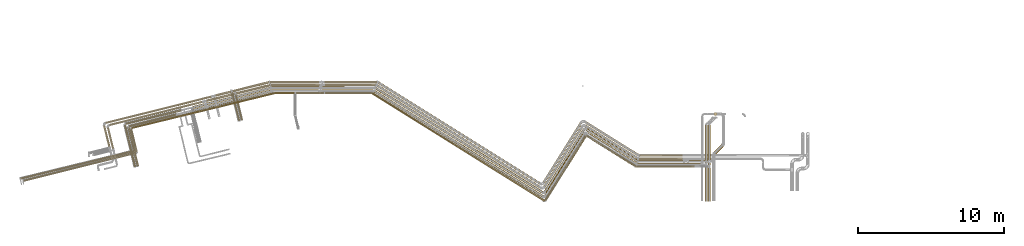
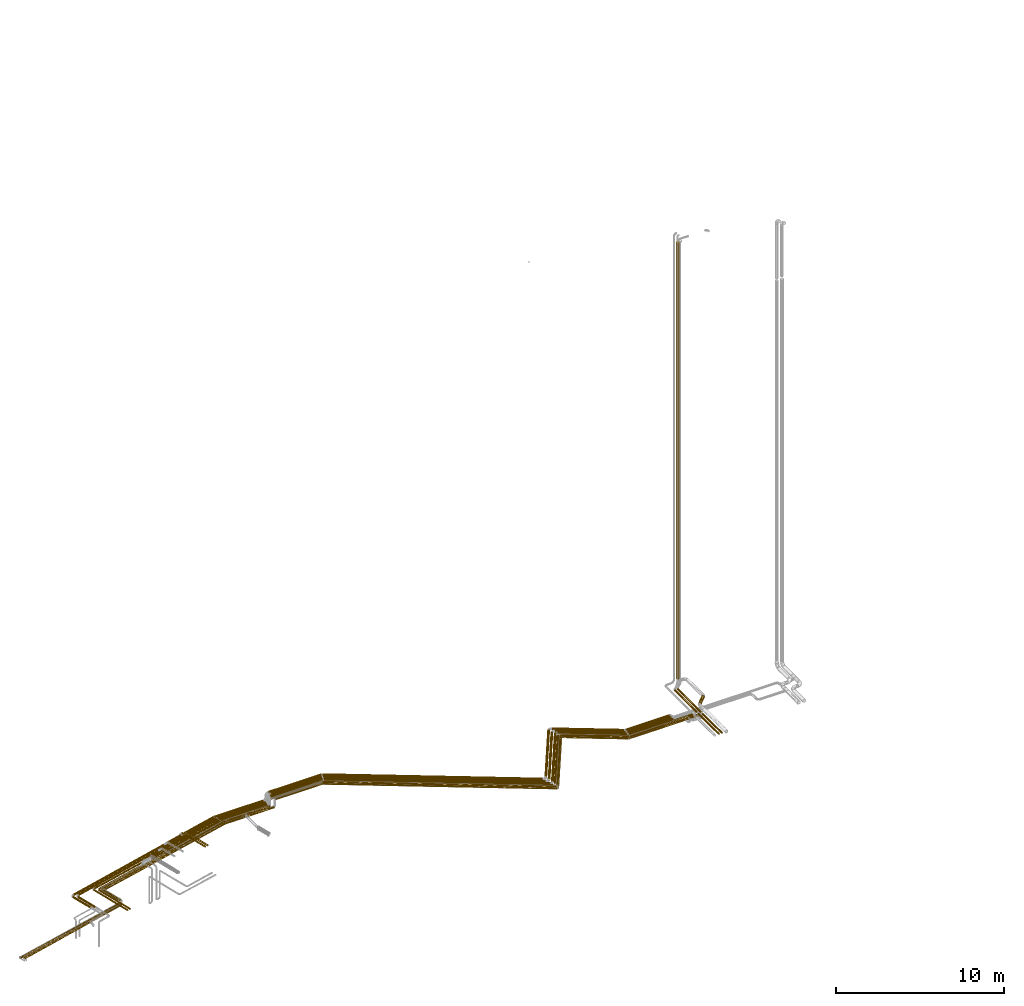
# One storey, part 1 of 93: 66 coverings.
"""IFC2X3 building model written with IfcOpenShell, lengths in millimetres."""

from ifc_helpers import new_model, entity, si_unit, converted_unit, derived_unit, direction, frame, origin, origin_2d_with_axis, place, context, subcontext, project, spatial, circle, extrude, element, save


model = new_model("IFC2X3")

# Units and contexts
model_context = context("Model", 3, precision=0.01, world=origin(), true_north=direction((6.12303176911189e-17, 1.0)))
body_context = subcontext(model_context, "Body", "Model", "MODEL_VIEW")
ifc_project = project(units=[si_unit("LENGTHUNIT", "METRE", prefix="MILLI"), si_unit("AREAUNIT", "SQUARE_METRE"), si_unit("VOLUMEUNIT", "CUBIC_METRE"), converted_unit("PLANEANGLEUNIT", "DEGREE", entity("IfcRatioMeasure", 0.0174532925199433), si_unit("PLANEANGLEUNIT", "RADIAN"), dimensions=[0, 0, 0, 0, 0, 0, 0]), si_unit("MASSUNIT", "GRAM", prefix="KILO"), derived_unit("MASSDENSITYUNIT", [(si_unit("MASSUNIT", "GRAM", prefix="KILO"), 1), (si_unit("LENGTHUNIT", "METRE"), -3)]), derived_unit("MOMENTOFINERTIAUNIT", [(si_unit("LENGTHUNIT", "METRE"), 4)]), si_unit("TIMEUNIT", "SECOND"), si_unit("FREQUENCYUNIT", "HERTZ"), si_unit("THERMODYNAMICTEMPERATUREUNIT", "DEGREE_CELSIUS"), derived_unit("THERMALTRANSMITTANCEUNIT", [(si_unit("MASSUNIT", "GRAM", prefix="KILO"), 1), (si_unit("THERMODYNAMICTEMPERATUREUNIT", "KELVIN"), -1), (si_unit("TIMEUNIT", "SECOND"), -3)]), derived_unit("VOLUMETRICFLOWRATEUNIT", [(si_unit("LENGTHUNIT", "METRE"), 3), (si_unit("TIMEUNIT", "SECOND"), -1)]), derived_unit("MASSFLOWRATEUNIT", [(si_unit("MASSUNIT", "GRAM", prefix="KILO"), 1), (si_unit("TIMEUNIT", "SECOND"), -1)]), derived_unit("ROTATIONALFREQUENCYUNIT", [(si_unit("TIMEUNIT", "SECOND"), -1)]), si_unit("ELECTRICCURRENTUNIT", "AMPERE"), si_unit("ELECTRICVOLTAGEUNIT", "VOLT"), si_unit("POWERUNIT", "WATT"), si_unit("FORCEUNIT", "NEWTON", prefix="KILO"), si_unit("ILLUMINANCEUNIT", "LUX"), si_unit("LUMINOUSFLUXUNIT", "LUMEN"), si_unit("LUMINOUSINTENSITYUNIT", "CANDELA"), derived_unit("USERDEFINED", [(si_unit("MASSUNIT", "GRAM", prefix="KILO"), -1), (si_unit("LENGTHUNIT", "METRE"), -2), (si_unit("TIMEUNIT", "SECOND"), 3), (si_unit("LUMINOUSFLUXUNIT", "LUMEN"), 1)]), derived_unit("LINEARVELOCITYUNIT", [(si_unit("LENGTHUNIT", "METRE"), 1), (si_unit("TIMEUNIT", "SECOND"), -1)]), si_unit("PRESSUREUNIT", "PASCAL"), derived_unit("USERDEFINED", [(si_unit("LENGTHUNIT", "METRE"), -2), (si_unit("MASSUNIT", "GRAM", prefix="KILO"), 1), (si_unit("TIMEUNIT", "SECOND"), -2)]), derived_unit("LINEARFORCEUNIT", [(si_unit("MASSUNIT", "GRAM", prefix="KILO"), 1), (si_unit("LENGTHUNIT", "METRE"), 1), (si_unit("TIMEUNIT", "SECOND"), -2), (si_unit("LENGTHUNIT", "METRE"), -1)]), derived_unit("PLANARFORCEUNIT", [(si_unit("MASSUNIT", "GRAM", prefix="KILO"), 1), (si_unit("LENGTHUNIT", "METRE"), 1), (si_unit("TIMEUNIT", "SECOND"), -2), (si_unit("LENGTHUNIT", "METRE"), -2)])], contexts=[model_context])

# Site, building, storey
site_placement = place(None, origin())
site = spatial("IfcSite", under=ifc_project, at=site_placement, CompositionType="ELEMENT")
building_placement = place(site_placement, origin())
building = spatial("IfcBuilding", under=site, at=building_placement, CompositionType="ELEMENT")
storey_placement = place(building_placement, frame((0.0, 0.0, -4200.0)))
storey = spatial("IfcBuildingStorey", under=building, at=storey_placement, CompositionType="ELEMENT", Elevation=-4200.0)

# Coverings
covering_1_placement = place(storey_placement, frame((16223.6, 8804.96, 2914.66)))
element("IfcCovering", 1, at=covering_1_placement, inside=storey, PredefinedType="INSULATION", context=body_context, shape_type="SweptSolid", body=[
    extrude(circle(Radius=84.5, at=origin_2d_with_axis()), frame((3445.16, 73.26, 86.1), z_axis=(-0.848048096872166, 0.529919263087781, 0.0), x_axis=(-0.529919263087781, -0.848048096872166, 0.0)), (0.0, 0.0, 1.0), 4007.77716045076),
])
covering_2_placement = place(storey_placement, frame((13365.87, 6651.78, 2914.66)))
element("IfcCovering", 2, at=covering_2_placement, inside=storey, PredefinedType="INSULATION", context=body_context, shape_type="SweptSolid", body=[
    extrude(circle(Radius=84.5, at=origin_2d_with_axis()), frame((73.26, 46.37, 86.1), z_axis=(0.529919264233208, 0.848048096156424, 0.0), x_axis=(0.848048096156424, -0.529919264233208, 0.0)), (0.0, 0.0, 1.0), 5029.99999999998),
])
covering_3_placement = place(storey_placement, frame((1670.12, 6586.73, 2913.9)))
element("IfcCovering", 3, at=covering_3_placement, inside=storey, PredefinedType="INSULATION", context=body_context, shape_type="SweptSolid", body=[
    extrude(circle(Radius=84.5, at=origin_2d_with_axis()), frame((11603.65, 73.26, 86.85), z_axis=(-0.848048094870504, 0.529919263429674, -5.5069602747006e-05), x_axis=(0.529919264233207, 0.848048096156425, 0.0)), (0.0, 0.0, 1.0), 13628.0909050597),
])
covering_4_placement = place(storey_placement, frame((-1871.09, 13813.91, 2913.9)))
element("IfcCovering", 4, at=covering_4_placement, inside=storey, PredefinedType="INSULATION", context=body_context, shape_type="SweptSolid", body=[
    extrude(circle(Radius=84.5, at=origin_2d_with_axis()), frame((0.0, 86.1, 86.1), z_axis=(1.0, 0.0, -7.50758540454034e-07), x_axis=(0.0, -1.0, 0.0)), (0.0, 0.0, 1.0), 3523.99516441944),
])
covering_5_placement = place(storey_placement, frame((19732.35, 8773.89, 2914.66)))
element("IfcCovering", 5, at=covering_5_placement, inside=storey, PredefinedType="INSULATION", context=body_context, shape_type="SweptSolid", body=[
    extrude(circle(Radius=84.5, at=origin_2d_with_axis()), frame((0.0, 86.1, 86.1), z_axis=(1.0, 0.0, 0.0), x_axis=(0.0, -1.0, 0.0)), (0.0, 0.0, 1.0), 4364.44138685684),
])
covering_6_placement = place(storey_placement, frame((24958.04, 9544.49, 2891.9)))
element("IfcCovering", 6, at=covering_6_placement, inside=storey, PredefinedType="INSULATION", context=body_context, shape_type="SweptSolid", body=[
    extrude(circle(Radius=106.5, at=origin_2d_with_axis()), frame((76.9, 76.9, 108.1), z_axis=(0.707106781186553, 0.707106781186542, 0.0), x_axis=(-0.707106781186542, 0.707106781186553, 0.0)), (0.0, 0.0, 1.0), 775.735931288089),
])
covering_7_placement = place(storey_placement, frame((19790.5, 8975.05, 2910.91)))
element("IfcCovering", 7, at=covering_7_placement, inside=storey, PredefinedType="INSULATION", context=body_context, shape_type="SweptSolid", body=[
    extrude(circle(Radius=84.5, at=origin_2d_with_axis()), frame((0.0, 86.1, 86.1), z_axis=(1.0, 0.0, 0.0), x_axis=(0.0, 1.0, 0.0)), (0.0, 0.0, 1.0), 3082.63986313707),
])
covering_8_placement = place(storey_placement, frame((16181.84, 9006.12, 2910.91)))
element("IfcCovering", 8, at=covering_8_placement, inside=storey, PredefinedType="INSULATION", context=body_context, shape_type="SweptSolid", body=[
    extrude(circle(Radius=84.5, at=origin_2d_with_axis()), frame((3545.07, 73.26, 86.1), z_axis=(-0.848048096872165, 0.529919263087784, 0.0), x_axis=(-0.529919263087784, -0.848048096872165, 0.0)), (0.0, 0.0, 1.0), 4125.59056056346),
])
covering_9_placement = place(storey_placement, frame((13334.7, 6932.33, 2910.91)))
element("IfcCovering", 9, at=covering_9_placement, inside=storey, PredefinedType="INSULATION", context=body_context, shape_type="SweptSolid", body=[
    extrude(circle(Radius=84.5, at=origin_2d_with_axis()), frame((73.26, 46.37, 86.1), z_axis=(0.529919264233209, 0.848048096156423, 0.0), x_axis=(0.848048096156423, -0.529919264233209, 0.0)), (0.0, 0.0, 1.0), 5010.0017049427),
])
covering_10_placement = place(storey_placement, frame((1774.02, 6867.28, 2910.91)))
element("IfcCovering", 10, at=covering_10_placement, inside=storey, PredefinedType="INSULATION", context=body_context, shape_type="SweptSolid", body=[
    extrude(circle(Radius=84.5, at=origin_2d_with_axis()), frame((11468.58, 73.26, 86.1), z_axis=(-0.848048096156424, 0.529919264233208, 0.0), x_axis=(0.0, 0.0, -1.0)), (0.0, 0.0, 1.0), 13468.8235901615),
])
covering_11_placement = place(storey_placement, frame((-1834.92, 14010.06, 2910.94)))
element("IfcCovering", 11, at=covering_11_placement, inside=storey, PredefinedType="INSULATION", context=body_context, shape_type="SweptSolid", body=[
    extrude(circle(Radius=84.5, at=origin_2d_with_axis()), frame((3591.85, 86.1, 86.1), z_axis=(-0.99999896917087, 0.00107763060458495, 0.000948878009774168), x_axis=(-0.00107763108971813, -0.999999419355449, 0.0)), (0.0, 0.0, 1.0), 3590.17075330023),
])
covering_12_placement = place(storey_placement, frame((24987.53, 12203.97, 3190.0)))
element("IfcCovering", 12, at=covering_12_placement, inside=storey, PredefinedType="INSULATION", context=body_context, shape_type="SweptSolid", body=[
    extrude(circle(Radius=110.0, at=origin_2d_with_axis()), frame((111.6, 111.6, 0.0)), (0.0, 0.0, 1.0), 31620.0),
])
covering_13_placement = place(storey_placement, frame((-7764.06, 13646.82, 2416.82)))
element("IfcCovering", 13, at=covering_13_placement, inside=storey, PredefinedType="INSULATION", context=body_context, shape_type="SweptSolid", body=[
    extrude(circle(Radius=81.5, at=origin_2d_with_axis()), frame((20.9, 80.78, 83.1), z_axis=(0.971553061175066, 0.236821975409198, 3.58419250346389e-05), x_axis=(0.236821975561314, -0.971553061799116, 0.0)), (0.0, 0.0, 1.0), 2394.20471743284),
])
covering_14_placement = place(storey_placement, frame((-16451.83, 11492.29, 2429.32)))
element("IfcCovering", 14, at=covering_14_placement, inside=storey, PredefinedType="INSULATION", context=body_context, shape_type="SweptSolid", body=[
    extrude(circle(Radius=69.0, at=origin_2d_with_axis()), frame((18.29, 68.55, 70.6), z_axis=(0.970295726276005, 0.241921895599632, 0.0), x_axis=(-0.241921895599632, 0.970295726276005, 0.0)), (0.0, 0.0, 1.0), 6535.06575644785),
])
covering_15_placement = place(storey_placement, frame((-7831.89, 11898.55, 2654.9)))
element("IfcCovering", 15, at=covering_15_placement, inside=storey, PredefinedType="INSULATION", context=body_context, shape_type="SweptSolid", body=[
    extrude(circle(Radius=43.5, at=origin_2d_with_axis()), frame((43.8, 1740.55, 45.1), z_axis=(0.241921895599631, -0.970295726276006, 0.0), x_axis=(0.970295726276006, 0.241921895599631, 0.0)), (0.0, 0.0, 1.0), 1781.33959077582),
])
covering_16_placement = place(storey_placement, frame((-9803.41, 13138.56, 2416.82)))
element("IfcCovering", 16, at=covering_16_placement, inside=storey, PredefinedType="INSULATION", context=body_context, shape_type="SweptSolid", body=[
    extrude(circle(Radius=81.5, at=origin_2d_with_axis()), frame((21.31, 80.67, 83.1), z_axis=(0.970295726276001, 0.241921895599651, 0.0), x_axis=(-0.171064612896004, 0.686102687806091, 0.707106781186546)), (0.0, 0.0, 1.0), 1971.35839123397),
])
covering_17_placement = place(storey_placement, frame((-5372.07, 14216.91, 2416.9)))
element("IfcCovering", 17, at=covering_17_placement, inside=storey, PredefinedType="INSULATION", context=body_context, shape_type="SweptSolid", body=[
    extrude(circle(Radius=81.5, at=origin_2d_with_axis()), frame((0.0, 83.1, 83.1), z_axis=(1.0, 0.0, 0.0), x_axis=(0.0, 1.0, 0.0)), (0.0, 0.0, 1.0), 3329.8857023589),
])
covering_18_placement = place(storey_placement, frame((1863.72, 7196.14, 2916.9)))
element("IfcCovering", 18, at=covering_18_placement, inside=storey, PredefinedType="INSULATION", context=body_context, shape_type="SweptSolid", body=[
    extrude(circle(Radius=81.5, at=origin_2d_with_axis()), frame((44.78, 7074.99, 83.1), z_axis=(0.848048096156426, -0.529919264233205, 0.0), x_axis=(0.529919264233205, 0.848048096156426, 0.0)), (0.0, 0.0, 1.0), 13217.6368280217),
])
covering_19_placement = place(storey_placement, frame((13308.79, 7282.51, 2916.9)))
element("IfcCovering", 19, at=covering_19_placement, inside=storey, PredefinedType="INSULATION", context=body_context, shape_type="SweptSolid", body=[
    extrude(circle(Radius=81.5, at=origin_2d_with_axis()), frame((70.71, 44.78, 83.1), z_axis=(0.529919264233208, 0.848048096156424, 0.0), x_axis=(-0.848048096156424, 0.529919264233208, 0.0)), (0.0, 0.0, 1.0), 4839.99999995205),
])
covering_20_placement = place(storey_placement, frame((16161.34, 9212.9, 2916.9)))
element("IfcCovering", 20, at=covering_20_placement, inside=storey, PredefinedType="INSULATION", context=body_context, shape_type="SweptSolid", body=[
    extrude(circle(Radius=81.5, at=origin_2d_with_axis()), frame((3579.42, 70.71, 83.1), z_axis=(-0.848048096156425, 0.529919264233206, 0.0), x_axis=(0.529919264233206, 0.848048096156425, 0.0)), (0.0, 0.0, 1.0), 4167.96244380158),
])
covering_21_placement = place(storey_placement, frame((19841.45, 9171.64, 2916.9)))
element("IfcCovering", 21, at=covering_21_placement, inside=storey, PredefinedType="INSULATION", context=body_context, shape_type="SweptSolid", body=[
    extrude(circle(Radius=81.5, at=origin_2d_with_axis()), frame((0.0, 83.1, 83.1), z_axis=(1.0, 0.0, 0.0), x_axis=(0.0, 1.0, 0.0)), (0.0, 0.0, 1.0), 3011.72234269005),
])
covering_22_placement = place(storey_placement, frame((24403.45, 8937.14, 2935.4)))
element("IfcCovering", 22, at=covering_22_placement, inside=storey, PredefinedType="INSULATION", context=body_context, shape_type="SweptSolid", body=[
    extrude(circle(Radius=63.0, at=origin_2d_with_axis()), frame((64.6, 0.0, 64.6), z_axis=(0.0, 1.0, 0.0), x_axis=(-1.0, 0.0, 0.0)), (0.0, 0.0, 1.0), 2647.17830176069),
])
covering_23_placement = place(storey_placement, frame((24403.45, 6345.74, 2935.4)))
element("IfcCovering", 23, at=covering_23_placement, inside=storey, PredefinedType="INSULATION", context=body_context, shape_type="SweptSolid", body=[
    extrude(circle(Radius=63.0, at=origin_2d_with_axis()), frame((64.6, 0.0, 64.6), z_axis=(0.0, 1.0, 0.0), x_axis=(-1.0, 0.0, 0.0)), (0.0, 0.0, 1.0), 2439.40034200199),
])
covering_24_placement = place(storey_placement, frame((19661.55, 8660.55, 2892.25)))
element("IfcCovering", 24, at=covering_24_placement, inside=storey, PredefinedType="INSULATION", context=body_context, shape_type="SweptSolid", body=[
    extrude(circle(Radius=49.0, at=origin_2d_with_axis()), frame((0.0, 50.6, 50.6), z_axis=(1.0, 0.0, 0.0), x_axis=(0.0, -1.0, 0.0)), (0.0, 0.0, 1.0), 3805.04533999816),
])
covering_25_placement = place(storey_placement, frame((16256.83, 8676.65, 2892.25)))
element("IfcCovering", 25, at=covering_25_placement, inside=storey, PredefinedType="INSULATION", context=body_context, shape_type="SweptSolid", body=[
    extrude(circle(Radius=49.0, at=origin_2d_with_axis()), frame((3374.52, 43.15, 50.6), z_axis=(-0.848048096872167, 0.529919263087781, 0.0), x_axis=(-0.529919263087781, -0.848048096872167, 0.0)), (0.0, 0.0, 1.0), 3946.65551305345),
])
covering_26_placement = place(storey_placement, frame((13407.19, 6355.78, 2892.25)))
element("IfcCovering", 26, at=covering_26_placement, inside=storey, PredefinedType="INSULATION", context=body_context, shape_type="SweptSolid", body=[
    extrude(circle(Radius=49.0, at=origin_2d_with_axis()), frame((43.15, 27.56, 50.6), z_axis=(0.529919264233211, 0.848048096156422, 0.0), x_axis=(0.848048096156422, -0.529919264233211, 0.0)), (0.0, 0.0, 1.0), 5199.86161627023),
])
covering_27_placement = place(storey_placement, frame((1539.96, 6322.06, 2892.25)))
element("IfcCovering", 27, at=covering_27_placement, inside=storey, PredefinedType="INSULATION", context=body_context, shape_type="SweptSolid", body=[
    extrude(circle(Radius=49.0, at=origin_2d_with_axis()), frame((27.56, 7419.28, 50.6), z_axis=(0.848048096156422, -0.529919264233212, 0.0), x_axis=(0.529919264233212, 0.848048096156422, 0.0)), (0.0, 0.0, 1.0), 13919.3436019751),
])
covering_28_placement = place(storey_placement, frame((-3645.84, 13699.41, 2342.25)))
element("IfcCovering", 28, at=covering_28_placement, inside=storey, PredefinedType="INSULATION", context=body_context, shape_type="SweptSolid", body=[
    extrude(circle(Radius=49.0, at=origin_2d_with_axis()), frame((0.0, 50.6, 50.6), z_axis=(1.0, 0.0, 0.0), x_axis=(0.0, 1.0, 0.0)), (0.0, 0.0, 1.0), 1883.00000000001),
])
covering_29_placement = place(storey_placement, frame((-15000.07, 10033.67, 2342.25)))
element("IfcCovering", 29, at=covering_29_placement, inside=storey, PredefinedType="INSULATION", context=body_context, shape_type="SweptSolid", body=[
    extrude(circle(Radius=49.0, at=origin_2d_with_axis()), frame((348.35, 13.05, 50.6), z_axis=(-0.233868385495283, 0.972268264557591, 0.0), x_axis=(-0.972268264557591, -0.233868385495283, 0.0)), (0.0, 0.0, 1.0), 1278.99033837842),
])
covering_30_placement = place(storey_placement, frame((24609.86, 8787.14, 2935.4)))
element("IfcCovering", 30, at=covering_30_placement, inside=storey, PredefinedType="INSULATION", context=body_context, shape_type="SweptSolid", body=[
    extrude(circle(Radius=63.0, at=origin_2d_with_axis()), frame((64.6, 0.0, 64.6), z_axis=(0.0, 1.0, 0.0), x_axis=(-1.0, 0.0, 0.0)), (0.0, 0.0, 1.0), 2807.17830176069),
])
covering_31_placement = place(storey_placement, frame((24609.86, 6345.74, 2935.4)))
element("IfcCovering", 31, at=covering_31_placement, inside=storey, PredefinedType="INSULATION", context=body_context, shape_type="SweptSolid", body=[
    extrude(circle(Radius=63.0, at=origin_2d_with_axis()), frame((64.6, 0.0, 64.6), z_axis=(0.0, 1.0, 0.0), x_axis=(-1.0, 0.0, 0.0)), (0.0, 0.0, 1.0), 2289.40034200199),
])
covering_32_placement = place(storey_placement, frame((19692.0, 8660.55, 3008.21)))
element("IfcCovering", 32, at=covering_32_placement, inside=storey, PredefinedType="INSULATION", context=body_context, shape_type="SweptSolid", body=[
    extrude(circle(Radius=49.0, at=origin_2d_with_axis()), frame((0.0, 50.6, 50.6), z_axis=(1.0, 0.0, 0.0), x_axis=(0.0, -1.0, 0.0)), (0.0, 0.0, 1.0), 3960.04533999814),
])
covering_33_placement = place(storey_placement, frame((16236.4, 8676.65, 3008.21)))
element("IfcCovering", 33, at=covering_33_placement, inside=storey, PredefinedType="INSULATION", context=body_context, shape_type="SweptSolid", body=[
    extrude(circle(Radius=49.0, at=origin_2d_with_axis()), frame((27.56, 2166.35, 50.6), z_axis=(0.848048096872167, -0.529919263087781, 0.0), x_axis=(-0.529919263087781, -0.848048096872167, 0.0)), (0.0, 0.0, 1.0), 4006.65551305341),
])
covering_34_placement = place(storey_placement, frame((13378.21, 6373.89, 3008.21)))
element("IfcCovering", 34, at=covering_34_placement, inside=storey, PredefinedType="INSULATION", context=body_context, shape_type="SweptSolid", body=[
    extrude(circle(Radius=49.0, at=origin_2d_with_axis()), frame((43.15, 27.56, 50.6), z_axis=(0.52991926423321, 0.848048096156423, 0.0), x_axis=(0.848048096156423, -0.52991926423321, 0.0)), (0.0, 0.0, 1.0), 5215.99892406455),
])
covering_35_placement = place(storey_placement, frame((1540.46, 6340.17, 3008.21)))
element("IfcCovering", 35, at=covering_35_placement, inside=storey, PredefinedType="INSULATION", context=body_context, shape_type="SweptSolid", body=[
    extrude(circle(Radius=49.0, at=origin_2d_with_axis()), frame((27.56, 7401.17, 50.6), z_axis=(0.848038093311225, -0.529935271795586, 0.0), x_axis=(-0.529935271795586, -0.848038093311225, 0.0)), (0.0, 0.0, 1.0), 13884.7471169057),
])
covering_36_placement = place(storey_placement, frame((-5093.58, 13699.41, 2508.21)))
element("IfcCovering", 36, at=covering_36_placement, inside=storey, PredefinedType="INSULATION", context=body_context, shape_type="SweptSolid", body=[
    extrude(circle(Radius=49.0, at=origin_2d_with_axis()), frame((0.0, 50.6, 50.6), z_axis=(1.0, 0.0, 0.0), x_axis=(0.0, 1.0, 0.0)), (0.0, 0.0, 1.0), 1333.74030890236),
])
covering_37_placement = place(storey_placement, frame((-15000.09, 9718.18, 2508.21)))
element("IfcCovering", 37, at=covering_37_placement, inside=storey, PredefinedType="INSULATION", context=body_context, shape_type="SweptSolid", body=[
    extrude(circle(Radius=49.0, at=origin_2d_with_axis()), frame((49.24, 1572.16, 50.6), z_axis=(0.233646720181625, -0.9723215569699, 0.0), x_axis=(-0.9723215569699, -0.233646720181625, 0.0)), (0.0, 0.0, 1.0), 1603.49585906828),
])
covering_38_placement = place(storey_placement, frame((-8007.16, 13793.55, 2416.9)))
element("IfcCovering", 38, at=covering_38_placement, inside=storey, PredefinedType="INSULATION", context=body_context, shape_type="SweptSolid", body=[
    extrude(circle(Radius=81.5, at=origin_2d_with_axis()), frame((21.31, 80.67, 83.1), z_axis=(0.970295726276005, 0.241921895599635, 0.0), x_axis=(0.241921895599635, -0.970295726276005, 0.0)), (0.0, 0.0, 1.0), 2563.34327595366),
])
covering_39_placement = place(storey_placement, frame((-16877.1, 10055.95, 2429.4)))
element("IfcCovering", 39, at=covering_39_placement, inside=storey, PredefinedType="INSULATION", context=body_context, shape_type="SweptSolid", body=[
    extrude(circle(Radius=69.0, at=origin_2d_with_axis()), frame((68.54, 1463.93, 70.6), z_axis=(0.242135671523188, -0.970242400937011, 0.0), x_axis=(0.970242400937011, 0.242135671523188, 0.0)), (0.0, 0.0, 1.0), 1489.96956280194),
])
covering_40_placement = place(storey_placement, frame((-16717.59, 11633.17, 2429.4)))
element("IfcCovering", 40, at=covering_40_placement, inside=storey, PredefinedType="INSULATION", context=body_context, shape_type="SweptSolid", body=[
    extrude(circle(Radius=69.0, at=origin_2d_with_axis()), frame((18.29, 68.55, 70.6), z_axis=(0.970295726275999, 0.241921895599659, 0.0), x_axis=(-0.241921895599659, 0.970295726275999, 0.0)), (0.0, 0.0, 1.0), 7450.83630867599),
])
covering_41_placement = place(storey_placement, frame((-9180.6, 13500.98, 2416.9)))
element("IfcCovering", 41, at=covering_41_placement, inside=storey, PredefinedType="INSULATION", context=body_context, shape_type="SweptSolid", body=[
    extrude(circle(Radius=81.5, at=origin_2d_with_axis()), frame((21.31, 80.67, 83.1), z_axis=(0.970295726276007, 0.241921895599625, 0.0), x_axis=(0.171064612895999, -0.686102687806064, -0.707106781186573)), (0.0, 0.0, 1.0), 1079.36675916112),
])
covering_42_placement = place(storey_placement, frame((-5452.68, 14416.91, 2416.9)))
element("IfcCovering", 42, at=covering_42_placement, inside=storey, PredefinedType="INSULATION", context=body_context, shape_type="SweptSolid", body=[
    extrude(circle(Radius=81.5, at=origin_2d_with_axis()), frame((0.0, 83.1, 83.1), z_axis=(1.0, 0.0, 0.0), x_axis=(0.0, 1.0, 0.0)), (0.0, 0.0, 1.0), 3370.91944682417),
])
covering_43_placement = place(storey_placement, frame((1944.14, 7482.1, 2916.9)))
element("IfcCovering", 43, at=covering_43_placement, inside=storey, PredefinedType="INSULATION", context=body_context, shape_type="SweptSolid", body=[
    extrude(circle(Radius=81.5, at=origin_2d_with_axis()), frame((11116.4, 70.71, 83.1), z_axis=(-0.848048096156424, 0.529919264233209, 0.0), x_axis=(0.529919264233209, 0.848048096156424, 0.0)), (0.0, 0.0, 1.0), 13055.4167034884),
])
covering_44_placement = place(storey_placement, frame((13251.65, 7568.47, 2916.9)))
element("IfcCovering", 44, at=covering_44_placement, inside=storey, PredefinedType="INSULATION", context=body_context, shape_type="SweptSolid", body=[
    extrude(circle(Radius=81.5, at=origin_2d_with_axis()), frame((70.71, 44.78, 83.1), z_axis=(0.52991926423321, 0.848048096156423, 0.0), x_axis=(-0.848048096156423, 0.52991926423321, 0.0)), (0.0, 0.0, 1.0), 4839.99999992639),
])
covering_45_placement = place(storey_placement, frame((16104.2, 9432.3, 2916.9)))
element("IfcCovering", 45, at=covering_45_placement, inside=storey, PredefinedType="INSULATION", context=body_context, shape_type="SweptSolid", body=[
    extrude(circle(Radius=81.5, at=origin_2d_with_axis()), frame((3685.94, 70.71, 83.1), z_axis=(-0.848048096156423, 0.529919264233209, 0.0), x_axis=(0.529919264233209, 0.848048096156423, 0.0)), (0.0, 0.0, 1.0), 4293.57017112024),
])
covering_46_placement = place(storey_placement, frame((19890.82, 9391.04, 2916.9)))
element("IfcCovering", 46, at=covering_46_placement, inside=storey, PredefinedType="INSULATION", context=body_context, shape_type="SweptSolid", body=[
    extrude(circle(Radius=81.5, at=origin_2d_with_axis()), frame((0.0, 83.1, 83.1), z_axis=(1.0, 0.0, 0.0), x_axis=(0.0, 1.0, 0.0)), (0.0, 0.0, 1.0), 2962.34690637158),
])
covering_47_placement = place(storey_placement, frame((-14922.13, 11309.83, 2508.21)))
element("IfcCovering", 47, at=covering_47_placement, inside=storey, PredefinedType="INSULATION", context=body_context, shape_type="SweptSolid", body=[
    extrude(circle(Radius=49.0, at=origin_2d_with_axis()), frame((13.2, 49.2, 50.6), z_axis=(0.971551074149834, 0.236830129667456, 0.0), x_axis=(-0.236830129667456, 0.971551074149834, 0.0)), (0.0, 0.0, 1.0), 10088.8628906297),
])
covering_48_placement = place(storey_placement, frame((-3645.84, 13699.41, 2508.21)))
element("IfcCovering", 48, at=covering_48_placement, inside=storey, PredefinedType="INSULATION", context=body_context, shape_type="SweptSolid", body=[
    extrude(circle(Radius=49.0, at=origin_2d_with_axis()), frame((0.0, 50.6, 50.6), z_axis=(1.0, 0.0, 0.0), x_axis=(0.0, 1.0, 0.0)), (0.0, 0.0, 1.0), 1583.00000000001),
])
covering_49_placement = place(storey_placement, frame((-5093.23, 13699.41, 2342.25)))
element("IfcCovering", 49, at=covering_49_placement, inside=storey, PredefinedType="INSULATION", context=body_context, shape_type="SweptSolid", body=[
    extrude(circle(Radius=49.0, at=origin_2d_with_axis()), frame((0.0, 50.6, 50.6), z_axis=(1.0, 0.0, 0.0), x_axis=(0.0, -1.0, 0.0)), (0.0, 0.0, 1.0), 1333.38964173774),
])
covering_50_placement = place(storey_placement, frame((-8074.57, 11850.17, 2654.9)))
element("IfcCovering", 50, at=covering_50_placement, inside=storey, PredefinedType="INSULATION", context=body_context, shape_type="SweptSolid", body=[
    extrude(circle(Radius=43.5, at=origin_2d_with_axis()), frame((43.8, 1935.56, 45.1), z_axis=(0.241921895599632, -0.970295726276005, 0.0), x_axis=(0.970295726276005, 0.241921895599632, 0.0)), (0.0, 0.0, 1.0), 1982.32667790187),
])
covering_51_placement = place(storey_placement, frame((-10754.69, 12682.28, 2414.21)))
element("IfcCovering", 51, at=covering_51_placement, inside=storey, PredefinedType="INSULATION", context=body_context, shape_type="SweptSolid", body=[
    extrude(circle(Radius=84.5, at=origin_2d_with_axis()), frame((22.04, 83.59, 86.1), z_axis=(0.970295726405392, 0.241921895080689, 0.0), x_axis=(-0.241921895080689, 0.970295726405392, 0.0)), (0.0, 0.0, 1.0), 5499.99479458199),
])
covering_52_placement = place(storey_placement, frame((-1701.76, 14416.91, 2916.9)))
element("IfcCovering", 52, at=covering_52_placement, inside=storey, PredefinedType="INSULATION", context=body_context, shape_type="SweptSolid", body=[
    extrude(circle(Radius=81.5, at=origin_2d_with_axis()), frame((0.0, 83.1, 83.1), z_axis=(1.0, 0.0, 0.0), x_axis=(0.0, -1.0, 0.0)), (0.0, 0.0, 1.0), 3590.0),
])
covering_53_placement = place(storey_placement, frame((-1662.18, 14216.91, 2916.9)))
element("IfcCovering", 53, at=covering_53_placement, inside=storey, PredefinedType="INSULATION", context=body_context, shape_type="SweptSolid", body=[
    extrude(circle(Radius=81.5, at=origin_2d_with_axis()), frame((0.0, 83.1, 83.1), z_axis=(1.0, 0.0, 0.0), x_axis=(0.0, -1.0, 0.0)), (0.0, 0.0, 1.0), 3470.00000000001),
])
covering_54_placement = place(storey_placement, frame((-5367.0, 14013.91, 2414.21)))
element("IfcCovering", 54, at=covering_54_placement, inside=storey, PredefinedType="INSULATION", context=body_context, shape_type="SweptSolid", body=[
    extrude(circle(Radius=84.5, at=origin_2d_with_axis()), frame((0.0, 86.1, 86.1), z_axis=(1.0, 0.0, 0.0), x_axis=(0.0, -1.0, 0.0)), (0.0, 0.0, 1.0), 3293.65038874736),
])
covering_55_placement = place(storey_placement, frame((-5347.47, 13813.91, 2417.55)))
element("IfcCovering", 55, at=covering_55_placement, inside=storey, PredefinedType="INSULATION", context=body_context, shape_type="SweptSolid", body=[
    extrude(circle(Radius=84.5, at=origin_2d_with_axis()), frame((0.0, 86.1, 86.1), z_axis=(1.0, 0.0, 0.0), x_axis=(0.0, -1.0, 0.0)), (0.0, 0.0, 1.0), 3236.37312185862),
])
covering_56_placement = place(storey_placement, frame((-14922.11, 11309.75, 2342.25)))
element("IfcCovering", 56, at=covering_56_placement, inside=storey, PredefinedType="INSULATION", context=body_context, shape_type="SweptSolid", body=[
    extrude(circle(Radius=49.0, at=origin_2d_with_axis()), frame((13.2, 49.2, 50.6), z_axis=(0.971551074149835, 0.23683012966745, 0.0), x_axis=(0.23683012966745, -0.971551074149835, 0.0)), (0.0, 0.0, 1.0), 10089.2038362497),
])
covering_57_placement = place(storey_placement, frame((-22517.29, 7842.38, 2242.25)))
element("IfcCovering", 57, at=covering_57_placement, inside=storey, PredefinedType="INSULATION", context=body_context, shape_type="SweptSolid", body=[
    extrude(circle(Radius=49.0, at=origin_2d_with_axis()), frame((13.2, 49.2, 50.6), z_axis=(0.971553776633291, 0.236819042962322, 0.0), x_axis=(0.236819042962322, -0.971553776633291, 0.0)), (0.0, 0.0, 1.0), 8081.84246750568),
])
covering_58_placement = place(storey_placement, frame((-22332.11, 7692.93, 2242.25)))
element("IfcCovering", 58, at=covering_58_placement, inside=storey, PredefinedType="INSULATION", context=body_context, shape_type="SweptSolid", body=[
    extrude(circle(Radius=49.0, at=origin_2d_with_axis()), frame((13.45, 49.14, 50.6), z_axis=(0.970295726276022, 0.241921895599564, 0.0), x_axis=(0.241921895599564, -0.970295726276022, 0.0)), (0.0, 0.0, 1.0), 7936.21539652437),
])
covering_59_placement = place(storey_placement, frame((-16611.43, 9922.49, 2429.32)))
element("IfcCovering", 59, at=covering_59_placement, inside=storey, PredefinedType="INSULATION", context=body_context, shape_type="SweptSolid", body=[
    extrude(circle(Radius=69.0, at=origin_2d_with_axis()), frame((68.63, 1456.52, 70.6), z_axis=(0.237217705772623, -0.971456428815589, 0.000408632885785687), x_axis=(0.971456509922902, 0.237217725578031, 0.0)), (0.0, 0.0, 1.0), 1480.8209980526),
])
covering_60_placement = place(storey_placement, frame((-15430.13, 8695.49, 2444.24)))
element("IfcCovering", 60, at=covering_60_placement, inside=storey, PredefinedType="INSULATION", context=body_context, shape_type="SweptSolid", body=[
    extrude(circle(Radius=55.0, at=origin_2d_with_axis()), frame((742.68, 14.53, 56.6), z_axis=(-0.235134964159672, 0.971962730061971, -3.31313153751575e-07), x_axis=(0.971962730062025, 0.235134964159685, 0.0)), (0.0, 0.0, 1.0), 2924.38590899762),
])
covering_61_placement = place(storey_placement, frame((-15184.02, 8742.55, 2443.14)))
element("IfcCovering", 61, at=covering_61_placement, inside=storey, PredefinedType="INSULATION", context=body_context, shape_type="SweptSolid", body=[
    extrude(circle(Radius=55.0, at=origin_2d_with_axis()), frame((691.08, 14.52, 56.6), z_axis=(-0.235049086006718, 0.97198349611196, 0.000102241762859156), x_axis=(-2.96098066233066e-05, 9.80284178904075e-05, -0.999999994756844)), (0.0, 0.0, 1.0), 2705.93955189196),
])
covering_62_placement = place(storey_placement, frame((-15088.39, 11423.84, 2443.4)))
element("IfcCovering", 62, at=covering_62_placement, inside=storey, PredefinedType="INSULATION", context=body_context, shape_type="SweptSolid", body=[
    extrude(circle(Radius=55.0, at=origin_2d_with_axis()), frame((14.9, 54.96, 56.61), z_axis=(0.970288537655733, 0.241950725704179, -5.01200914775057e-06), x_axis=(-0.241950725707218, 0.97028853766792, 0.0)), (0.0, 0.0, 1.0), 3275.77869410409),
])
covering_63_placement = place(storey_placement, frame((-15334.59, 11588.01, 2444.24)))
element("IfcCovering", 63, at=covering_63_placement, inside=storey, PredefinedType="INSULATION", context=body_context, shape_type="SweptSolid", body=[
    extrude(circle(Radius=55.0, at=origin_2d_with_axis()), frame((14.62, 55.03, 56.6), z_axis=(0.971551075195952, 0.236830125178739, 9.66501229446896e-06), x_axis=(9.39005308691199e-06, 2.28896607166004e-06, -1.0)), (0.0, 0.0, 1.0), 3891.90294438014),
])
covering_64_placement = place(storey_placement, frame((23281.68, 8975.05, 2601.77)))
element("IfcCovering", 64, at=covering_64_placement, inside=storey, PredefinedType="INSULATION", context=body_context, shape_type="SweptSolid", body=[
    extrude(circle(Radius=84.5, at=origin_2d_with_axis()), frame((0.0, 86.1, 86.1), z_axis=(1.0, 0.0, 0.0), x_axis=(0.0, -1.0, 0.0)), (0.0, 0.0, 1.0), 1332.01994670235),
])
covering_65_placement = place(storey_placement, frame((-10824.52, 12460.16, 2417.55)))
element("IfcCovering", 65, at=covering_65_placement, inside=storey, PredefinedType="INSULATION", context=body_context, shape_type="SweptSolid", body=[
    extrude(circle(Radius=84.5, at=origin_2d_with_axis()), frame((22.04, 83.59, 86.1), z_axis=(0.970302633072812, 0.241894192265893, 0.0), x_axis=(0.241894192265893, -0.970302633072812, 0.0)), (0.0, 0.0, 1.0), 5592.05871780592),
])
covering_66_placement = place(storey_placement, frame((-1648.84, 13699.41, 2892.25)))
element("IfcCovering", 66, at=covering_66_placement, inside=storey, PredefinedType="INSULATION", context=body_context, shape_type="SweptSolid", body=[
    extrude(circle(Radius=49.0, at=origin_2d_with_axis()), frame((0.0, 50.6, 50.6), z_axis=(1.0, 0.0, 0.0), x_axis=(0.0, -1.0, 0.0)), (0.0, 0.0, 1.0), 3186.15832154256),
])

save(model, "model.ifc")
